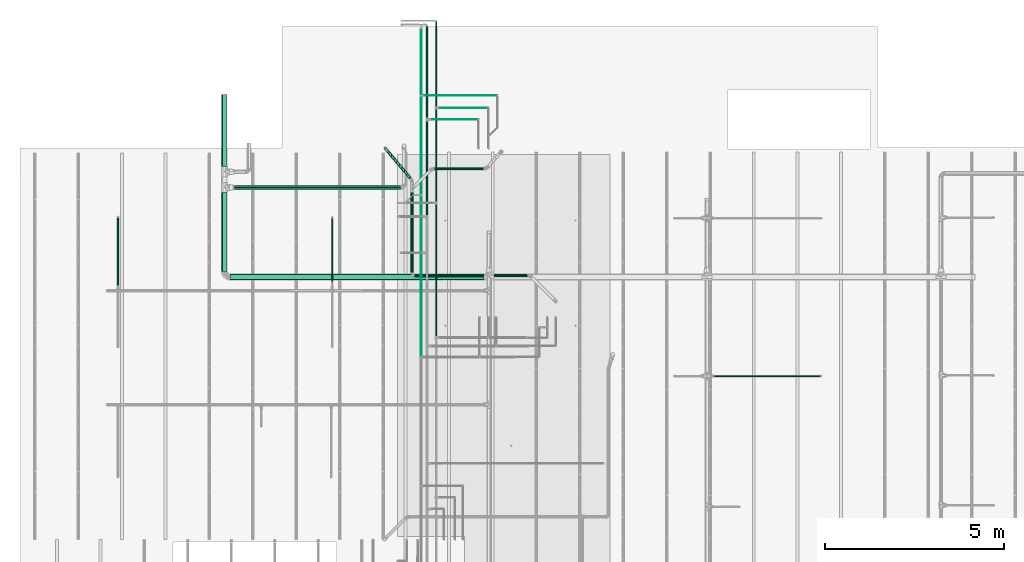
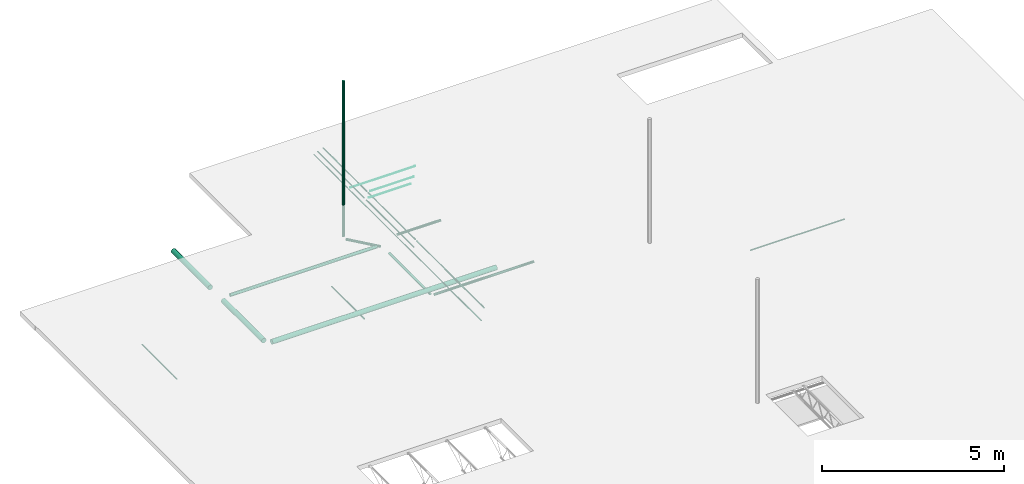
# One storey, part 6 of 173: 23 flow segments.
"""IFC2X3 building model written with IfcOpenShell, lengths in feet."""

from ifc_helpers import new_model, entity, si_unit, converted_unit, derived_unit, direction, frame, origin, origin_2d_with_axis, place, context, subcontext, project, spatial, circle, extrude, source, transform, mapped, type_object, type_shapes, element, save


model = new_model("IFC2X3")

# Units and contexts
model_context = context("Model", 3, precision=0.0001, world=origin(), true_north=direction((6.12303176911189e-17, 1.0)))
body_context = subcontext(model_context, "Body", "Model", "MODEL_VIEW")
ifc_project = project(units=[converted_unit("LENGTHUNIT", "FOOT", entity("IfcRatioMeasure", 0.3048), si_unit("LENGTHUNIT", "METRE"), dimensions=[1, 0, 0, 0, 0, 0, 0]), converted_unit("AREAUNIT", "SQUARE FOOT", entity("IfcRatioMeasure", 0.09290304), si_unit("AREAUNIT", "SQUARE_METRE"), dimensions=[2, 0, 0, 0, 0, 0, 0]), converted_unit("VOLUMEUNIT", "CUBIC FOOT", entity("IfcRatioMeasure", 0.028316846592), si_unit("VOLUMEUNIT", "CUBIC_METRE"), dimensions=[3, 0, 0, 0, 0, 0, 0]), converted_unit("PLANEANGLEUNIT", "DEGREE", entity("IfcRatioMeasure", 0.0174532925199433), si_unit("PLANEANGLEUNIT", "RADIAN"), dimensions=[0, 0, 0, 0, 0, 0, 0]), si_unit("MASSUNIT", "GRAM", prefix="KILO"), derived_unit("MASSDENSITYUNIT", [(si_unit("MASSUNIT", "GRAM", prefix="KILO"), 1), (si_unit("LENGTHUNIT", "METRE"), -3)]), si_unit("TIMEUNIT", "SECOND"), si_unit("FREQUENCYUNIT", "HERTZ"), si_unit("THERMODYNAMICTEMPERATUREUNIT", "DEGREE_CELSIUS"), derived_unit("THERMALTRANSMITTANCEUNIT", [(si_unit("MASSUNIT", "GRAM", prefix="KILO"), 1), (si_unit("THERMODYNAMICTEMPERATUREUNIT", "KELVIN"), -1), (si_unit("TIMEUNIT", "SECOND"), -3)]), derived_unit("VOLUMETRICFLOWRATEUNIT", [(si_unit("LENGTHUNIT", "METRE"), 3), (si_unit("TIMEUNIT", "SECOND"), -1)]), si_unit("ELECTRICCURRENTUNIT", "AMPERE"), si_unit("ELECTRICVOLTAGEUNIT", "VOLT"), si_unit("POWERUNIT", "WATT"), si_unit("FORCEUNIT", "NEWTON"), si_unit("ILLUMINANCEUNIT", "LUX"), si_unit("LUMINOUSFLUXUNIT", "LUMEN"), si_unit("LUMINOUSINTENSITYUNIT", "CANDELA"), derived_unit("USERDEFINED", [(si_unit("MASSUNIT", "GRAM", prefix="KILO"), -1), (si_unit("LENGTHUNIT", "METRE"), -2), (si_unit("TIMEUNIT", "SECOND"), 3), (si_unit("LUMINOUSFLUXUNIT", "LUMEN"), 1)]), derived_unit("LINEARVELOCITYUNIT", [(si_unit("LENGTHUNIT", "METRE"), 1), (si_unit("TIMEUNIT", "SECOND"), -1)]), si_unit("PRESSUREUNIT", "PASCAL"), derived_unit("USERDEFINED", [(si_unit("LENGTHUNIT", "METRE"), -2), (si_unit("MASSUNIT", "GRAM", prefix="KILO"), 1), (si_unit("TIMEUNIT", "SECOND"), -2)])], contexts=[model_context])

# Site, building, storey
site_placement = place(None, origin())
site = spatial("IfcSite", under=ifc_project, at=site_placement, CompositionType="ELEMENT")
building_placement = place(site_placement, origin())
building = spatial("IfcBuilding", under=site, at=building_placement, CompositionType="ELEMENT")
storey_placement = place(building_placement, frame((0.0, 0.0, 8.0)))
storey = spatial("IfcBuildingStorey", under=building, at=storey_placement, Name="REF", CompositionType="ELEMENT", Elevation=8.0)

# Flow segments
pipe_segment_type_1 = type_object("IfcPipeSegmentType", Name="Pipe Types:Standard", PredefinedType="NOTDEFINED")
shared_shape_1 = source(origin(), body_context, "Body", "SweptSolid", [
    extrude(circle(Radius=0.130208333333333, at=origin_2d_with_axis()), frame((-3.68513296929002, 42.8931070869327, 9.58398437499999), z_axis=(0.0, 1.0, 0.0), x_axis=(-1.0, 0.0, 0.0)), (0.0, 0.0, 1.0), 7.37635498552616),
])
type_shapes(pipe_segment_type_1, [shared_shape_1])
flow_segment_1_placement = place(storey_placement, frame((0.0, 0.0, -8.0)))
element("IfcFlowSegment", 1, at=flow_segment_1_placement, inside=storey, type_object=pipe_segment_type_1, Name="Pipe Types:Standard:Standard : Pipe Types:Standard", ObjectType="Standard : Pipe Types:Standard", context=body_context, shape_type="MappedRepresentation", body=[
    mapped(shared_shape_1, transform((0.0, 0.0, 0.0), scale=1.0)),
])
pipe_segment_type_2 = type_object("IfcPipeSegmentType", Name="Pipe Types:Standard", PredefinedType="NOTDEFINED")
shared_shape_2 = source(origin(), body_context, "Body", "SweptSolid", [
    extrude(circle(Radius=0.130208333333333, at=origin_2d_with_axis()), frame((-5.96852925804905, 54.1150089853566, 9.58398437499999), z_axis=(0.642787609686544, -0.766044443118974, 0.0), x_axis=(0.766044443118974, 0.642787609686544, 0.0)), (0.0, 0.0, 1.0), 3.30299018056606),
])
type_shapes(pipe_segment_type_2, [shared_shape_2])
flow_segment_2_placement = place(storey_placement, frame((0.0, 0.0, -8.0)))
element("IfcFlowSegment", 2, at=flow_segment_2_placement, inside=storey, type_object=pipe_segment_type_2, Name="Pipe Types:Standard:Standard : Pipe Types:Standard", ObjectType="Standard : Pipe Types:Standard", context=body_context, shape_type="MappedRepresentation", body=[
    mapped(shared_shape_2, transform((0.0, 0.0, 0.0), scale=1.0)),
])
pipe_segment_type_3 = type_object("IfcPipeSegmentType", Name="Pipe Types:Standard", PredefinedType="NOTDEFINED")
shared_shape_3 = source(origin(), body_context, "Body", "SweptSolid", [
    extrude(circle(Radius=0.130208333333333, at=origin_2d_with_axis()), frame((-6.12880438382389, 54.3060174423022, 9.83332820702099)), (0.0, 0.0, 1.0), 17.0839895013123),
])
type_shapes(pipe_segment_type_3, [shared_shape_3])
flow_segment_3_placement = place(storey_placement, frame((0.0, 0.0, -8.0)))
element("IfcFlowSegment", 3, at=flow_segment_3_placement, inside=storey, type_object=pipe_segment_type_3, Name="Pipe Types:Standard:Standard : Pipe Types:Standard", ObjectType="Standard : Pipe Types:Standard", context=body_context, shape_type="MappedRepresentation", body=[
    mapped(shared_shape_3, transform((0.0, 0.0, 0.0), scale=1.0)),
])
pipe_segment_type_4 = type_object("IfcPipeSegmentType", Name="Pipe Types:Standard", PredefinedType="NOTDEFINED")
shared_shape_4 = source(origin(), body_context, "Body", "SweptSolid", [
    extrude(circle(Radius=0.255208333333333, at=origin_2d_with_axis()), frame((-20.9063914924708, 43.0019225797628, 10.4173177083333), z_axis=(0.0, 1.0, 0.0), x_axis=(-1.0, 0.0, 0.0)), (0.0, 0.0, 1.0), 7.24870720132155),
])
type_shapes(pipe_segment_type_4, [shared_shape_4])
flow_segment_4_placement = place(storey_placement, frame((0.0, 0.0, -8.0)))
element("IfcFlowSegment", 4, at=flow_segment_4_placement, inside=storey, type_object=pipe_segment_type_4, Name="Pipe Types:Standard:Standard : Pipe Types:Standard", ObjectType="Standard : Pipe Types:Standard", context=body_context, shape_type="MappedRepresentation", body=[
    mapped(shared_shape_4, transform((0.0, 0.0, 0.0), scale=1.0)),
])
pipe_segment_type_5 = type_object("IfcPipeSegmentType", Name="Pipe Types:Standard", PredefinedType="NOTDEFINED")
shared_shape_5 = source(origin(), body_context, "Body", "SweptSolid", [
    extrude(circle(Radius=0.171875, at=origin_2d_with_axis()), frame((-19.977913802182, 50.7197898860712, 10.4173177083333), z_axis=(1.0, 0.0, 0.0), x_axis=(0.0, -1.0, 0.0)), (0.0, 0.0, 1.0), 15.2368766404199),
])
type_shapes(pipe_segment_type_5, [shared_shape_5])
flow_segment_5_placement = place(storey_placement, frame((0.0, 0.0, -8.0)))
element("IfcFlowSegment", 5, at=flow_segment_5_placement, inside=storey, type_object=pipe_segment_type_5, Name="Pipe Types:Standard:Standard : Pipe Types:Standard", ObjectType="Standard : Pipe Types:Standard", context=body_context, shape_type="MappedRepresentation", body=[
    mapped(shared_shape_5, transform((0.0, 0.0, 0.0), scale=1.0)),
])
pipe_segment_type_6 = type_object("IfcPipeSegmentType", Name="Pipe Types:Standard", PredefinedType="NOTDEFINED")
shared_shape_6 = source(origin(), body_context, "Body", "SweptSolid", [
    extrude(circle(Radius=0.046875, at=origin_2d_with_axis()), frame((-30.6818340641607, 41.7044138566689, 10.4173177083334), z_axis=(0.0, 1.0, 0.0), x_axis=(1.0, 0.0, 0.0)), (0.0, 0.0, 1.0), 6.24139408619316),
])
type_shapes(pipe_segment_type_6, [shared_shape_6])
flow_segment_6_placement = place(storey_placement, frame((0.0, 0.0, -8.0)))
element("IfcFlowSegment", 6, at=flow_segment_6_placement, inside=storey, type_object=pipe_segment_type_6, Name="Pipe Types:Standard:Standard : Pipe Types:Standard", ObjectType="Standard : Pipe Types:Standard", context=body_context, shape_type="MappedRepresentation", body=[
    mapped(shared_shape_6, transform((0.0, 0.0, 0.0), scale=1.0)),
])
pipe_segment_type_7 = type_object("IfcPipeSegmentType", Name="Pipe Types:Standard", PredefinedType="NOTDEFINED")
shared_shape_7 = source(origin(), body_context, "Body", "SweptSolid", [
    extrude(circle(Radius=0.046875, at=origin_2d_with_axis()), frame((-11.0151673974942, 42.0771172687423, 9.91731770833333), z_axis=(0.0, 1.0, 0.0), x_axis=(1.0, 0.0, 0.0)), (0.0, 0.0, 1.0), 5.83595800524938),
])
type_shapes(pipe_segment_type_7, [shared_shape_7])
flow_segment_7_placement = place(storey_placement, frame((0.0, 0.0, -8.0)))
element("IfcFlowSegment", 7, at=flow_segment_7_placement, inside=storey, type_object=pipe_segment_type_7, Name="Pipe Types:Standard:Standard : Pipe Types:Standard", ObjectType="Standard : Pipe Types:Standard", context=body_context, shape_type="MappedRepresentation", body=[
    mapped(shared_shape_7, transform((0.0, 0.0, 0.0), scale=1.0)),
])
pipe_segment_type_8 = type_object("IfcPipeSegmentType", Name="Pipe Types:Standard", PredefinedType="NOTDEFINED")
shared_shape_8 = source(origin(), body_context, "Body", "SweptSolid", [
    extrude(circle(Radius=0.046875, at=origin_2d_with_axis()), frame((24.0754645115229, 33.4088982913682, 10.4173177083333), z_axis=(1.0, 0.0, 0.0), x_axis=(0.0, -1.0, 0.0)), (0.0, 0.0, 1.0), 9.7388451443569),
])
type_shapes(pipe_segment_type_8, [shared_shape_8])
flow_segment_8_placement = place(storey_placement, frame((0.0, 0.0, -8.0)))
element("IfcFlowSegment", 8, at=flow_segment_8_placement, inside=storey, type_object=pipe_segment_type_8, Name="Pipe Types:Standard:Standard : Pipe Types:Standard", ObjectType="Standard : Pipe Types:Standard", context=body_context, shape_type="MappedRepresentation", body=[
    mapped(shared_shape_8, transform((0.0, 0.0, 0.0), scale=1.0)),
])
pipe_segment_type_9 = type_object("IfcPipeSegmentType", Name="Pipe Types:Standard", PredefinedType="NOTDEFINED")
shared_shape_9 = source(origin(), body_context, "Body", "SweptSolid", [
    extrude(circle(Radius=0.0677083333333333, at=origin_2d_with_axis()), frame((-2.31230977659058, 57.1596919829846, 11.0), z_axis=(0.0, 1.0, 0.0), x_axis=(1.0, 0.0, 0.0)), (0.0, 0.0, 1.0), 8.38727033927112),
])
type_shapes(pipe_segment_type_9, [shared_shape_9])
flow_segment_9_placement = place(storey_placement, frame((0.0, 0.0, -8.0)))
element("IfcFlowSegment", 9, at=flow_segment_9_placement, inside=storey, type_object=pipe_segment_type_9, Name="Pipe Types:Standard:Standard : Pipe Types:Standard", ObjectType="Standard : Pipe Types:Standard", context=body_context, shape_type="MappedRepresentation", body=[
    mapped(shared_shape_9, transform((0.0, 0.0, 0.0), scale=1.0)),
])
pipe_segment_type_10 = type_object("IfcPipeSegmentType", Name="Pipe Types:Standard", PredefinedType="NOTDEFINED")
shared_shape_10 = source(origin(), body_context, "Body", "SweptSolid", [
    extrude(circle(Radius=0.0260416666666667, at=origin_2d_with_axis()), frame((-1.91532814929397, 56.9726841089689, 11.0), z_axis=(1.0, 0.0, 0.0), x_axis=(0.0, -1.0, 0.0)), (0.0, 0.0, 1.0), 4.3046785289534),
])
type_shapes(pipe_segment_type_10, [shared_shape_10])
flow_segment_10_placement = place(storey_placement, frame((0.0, 0.0, -8.0)))
element("IfcFlowSegment", 10, at=flow_segment_10_placement, inside=storey, type_object=pipe_segment_type_10, Name="Pipe Types:Standard:Standard : Pipe Types:Standard", ObjectType="Standard : Pipe Types:Standard", context=body_context, shape_type="MappedRepresentation", body=[
    mapped(shared_shape_10, transform((0.0, 0.0, 0.0), scale=1.0)),
])
pipe_segment_type_11 = type_object("IfcPipeSegmentType", Name="Pipe Types:Standard", PredefinedType="NOTDEFINED")
shared_shape_11 = source(origin(), body_context, "Body", "SweptSolid", [
    extrude(circle(Radius=0.0677083333333333, at=origin_2d_with_axis()), frame((-2.31230977659057, 48.214836814253, 11.0), z_axis=(0.0, 1.0, 0.0), x_axis=(1.0, 0.0, 0.0)), (0.0, 0.0, 1.0), 8.57083942070012),
])
type_shapes(pipe_segment_type_11, [shared_shape_11])
flow_segment_11_placement = place(storey_placement, frame((0.0, 0.0, -8.0)))
element("IfcFlowSegment", 11, at=flow_segment_11_placement, inside=storey, type_object=pipe_segment_type_11, Name="Pipe Types:Standard:Standard : Pipe Types:Standard", ObjectType="Standard : Pipe Types:Standard", context=body_context, shape_type="MappedRepresentation", body=[
    mapped(shared_shape_11, transform((0.0, 0.0, 0.0), scale=1.0)),
])
pipe_segment_type_12 = type_object("IfcPipeSegmentType", Name="Pipe Types:Standard", PredefinedType="NOTDEFINED")
shared_shape_12 = source(origin(), body_context, "Body", "SweptSolid", [
    extrude(circle(Radius=0.046875, at=origin_2d_with_axis()), frame((-1.47897644325722, 37.0434757378257, 10.8333333333333), z_axis=(0.0, 1.0, 0.0), x_axis=(-1.0, 0.0, 0.0)), (0.0, 0.0, 1.0), 12.1357056652208),
])
type_shapes(pipe_segment_type_12, [shared_shape_12])
flow_segment_12_placement = place(storey_placement, frame((0.0, 0.0, -8.0)))
element("IfcFlowSegment", 12, at=flow_segment_12_placement, inside=storey, type_object=pipe_segment_type_12, Name="Pipe Types:Standard:Standard : Pipe Types:Standard", ObjectType="Standard : Pipe Types:Standard", context=body_context, shape_type="MappedRepresentation", body=[
    mapped(shared_shape_12, transform((0.0, 0.0, 0.0), scale=1.0)),
])
pipe_segment_type_13 = type_object("IfcPipeSegmentType", Name="Pipe Types:Standard", PredefinedType="NOTDEFINED")
shared_shape_13 = source(origin(), body_context, "Body", "SweptSolid", [
    extrude(circle(Radius=0.046875, at=origin_2d_with_axis()), frame((-1.47897644325722, 49.4285252350675, 10.8333333333333), z_axis=(0.0, 1.0, 0.0), x_axis=(-1.0, 0.0, 0.0)), (0.0, 0.0, 1.0), 8.45626372999633),
])
type_shapes(pipe_segment_type_13, [shared_shape_13])
flow_segment_13_placement = place(storey_placement, frame((0.0, 0.0, -8.0)))
element("IfcFlowSegment", 13, at=flow_segment_13_placement, inside=storey, type_object=pipe_segment_type_13, Name="Pipe Types:Standard:Standard : Pipe Types:Standard", ObjectType="Standard : Pipe Types:Standard", context=body_context, shape_type="MappedRepresentation", body=[
    mapped(shared_shape_13, transform((0.0, 0.0, 0.0), scale=1.0)),
])
pipe_segment_type_14 = type_object("IfcPipeSegmentType", Name="Pipe Types:Standard", PredefinedType="NOTDEFINED")
shared_shape_14 = source(origin(), body_context, "Body", "SweptSolid", [
    extrude(circle(Radius=0.0260416666666667, at=origin_2d_with_axis()), frame((-1.186981692601, 58.0094608810743, 10.8333333333333), z_axis=(1.0, 0.0, 0.0), x_axis=(0.0, -1.0, 0.0)), (0.0, 0.0, 1.0), 4.49299873892711),
])
type_shapes(pipe_segment_type_14, [shared_shape_14])
flow_segment_14_placement = place(storey_placement, frame((0.0, 0.0, -8.0)))
element("IfcFlowSegment", 14, at=flow_segment_14_placement, inside=storey, type_object=pipe_segment_type_14, Name="Pipe Types:Standard:Standard : Pipe Types:Standard", ObjectType="Standard : Pipe Types:Standard", context=body_context, shape_type="MappedRepresentation", body=[
    mapped(shared_shape_14, transform((0.0, 0.0, 0.0), scale=1.0)),
])
pipe_segment_type_15 = type_object("IfcPipeSegmentType", Name="Pipe Types:Standard", PredefinedType="NOTDEFINED")
shared_shape_15 = source(origin(), body_context, "Body", "SweptSolid", [
    extrude(circle(Radius=0.046875, at=origin_2d_with_axis()), frame((-1.47897644325719, 58.1341327970848, 10.8333333333333), z_axis=(0.0, 1.0, 0.0), x_axis=(-1.0, 0.0, 0.0)), (0.0, 0.0, 1.0), 7.83145811302411),
])
type_shapes(pipe_segment_type_15, [shared_shape_15])
flow_segment_15_placement = place(storey_placement, frame((0.0, 0.0, -8.0)))
element("IfcFlowSegment", 15, at=flow_segment_15_placement, inside=storey, type_object=pipe_segment_type_15, Name="Pipe Types:Standard:Standard : Pipe Types:Standard", ObjectType="Standard : Pipe Types:Standard", context=body_context, shape_type="MappedRepresentation", body=[
    mapped(shared_shape_15, transform((0.0, 0.0, 0.0), scale=1.0)),
])
pipe_segment_type_16 = type_object("IfcPipeSegmentType", Name="Pipe Types:Standard", PredefinedType="NOTDEFINED")
shared_shape_16 = source(origin(), body_context, "Body", "SweptSolid", [
    extrude(circle(Radius=0.0364583333333333, at=origin_2d_with_axis()), frame((-2.82504298847784, 35.2338590686775, 11.0), z_axis=(0.0, 1.0, 0.0), x_axis=(-1.0, 0.0, 0.0)), (0.0, 0.0, 1.0), 14.698453585842),
])
type_shapes(pipe_segment_type_16, [shared_shape_16])
flow_segment_16_placement = place(storey_placement, frame((0.0, 0.0, -8.0)))
element("IfcFlowSegment", 16, at=flow_segment_16_placement, inside=storey, type_object=pipe_segment_type_16, Name="Pipe Types:Standard:Standard : Pipe Types:Standard", ObjectType="Standard : Pipe Types:Standard", context=body_context, shape_type="MappedRepresentation", body=[
    mapped(shared_shape_16, transform((0.0, 0.0, 0.0), scale=1.0)),
])
pipe_segment_type_17 = type_object("IfcPipeSegmentType", Name="Pipe Types:Standard", PredefinedType="NOTDEFINED")
shared_shape_17 = source(origin(), body_context, "Body", "SweptSolid", [
    extrude(circle(Radius=0.0364583333333333, at=origin_2d_with_axis()), frame((-2.82504298847784, 50.1226013684303, 11.0), z_axis=(0.0, 1.0, 0.0), x_axis=(-1.0, 0.0, 0.0)), (0.0, 0.0, 1.0), 8.95244134638102),
])
type_shapes(pipe_segment_type_17, [shared_shape_17])
flow_segment_17_placement = place(storey_placement, frame((0.0, 0.0, -8.0)))
element("IfcFlowSegment", 17, at=flow_segment_17_placement, inside=storey, type_object=pipe_segment_type_17, Name="Pipe Types:Standard:Standard : Pipe Types:Standard", ObjectType="Standard : Pipe Types:Standard", context=body_context, shape_type="MappedRepresentation", body=[
    mapped(shared_shape_17, transform((0.0, 0.0, 0.0), scale=1.0)),
])
pipe_segment_type_18 = type_object("IfcPipeSegmentType", Name="Pipe Types:Standard", PredefinedType="NOTDEFINED")
shared_shape_18 = source(origin(), body_context, "Body", "SweptSolid", [
    extrude(circle(Radius=0.0260416666666667, at=origin_2d_with_axis()), frame((-2.60522671551191, 59.1701870717667, 11.0), z_axis=(1.0, 0.0, 0.0), x_axis=(0.0, -1.0, 0.0)), (0.0, 0.0, 1.0), 6.73184388328407),
])
type_shapes(pipe_segment_type_18, [shared_shape_18])
flow_segment_18_placement = place(storey_placement, frame((0.0, 0.0, -8.0)))
element("IfcFlowSegment", 18, at=flow_segment_18_placement, inside=storey, type_object=pipe_segment_type_18, Name="Pipe Types:Standard:Standard : Pipe Types:Standard", ObjectType="Standard : Pipe Types:Standard", context=body_context, shape_type="MappedRepresentation", body=[
    mapped(shared_shape_18, transform((0.0, 0.0, 0.0), scale=1.0)),
])
pipe_segment_type_19 = type_object("IfcPipeSegmentType", Name="Pipe Types:Standard", PredefinedType="NOTDEFINED")
shared_shape_19 = source(origin(), body_context, "Body", "SweptSolid", [
    extrude(circle(Radius=0.0364583333333333, at=origin_2d_with_axis()), frame((-2.82504298847784, 59.2653314287221, 11.0), z_axis=(0.0, 1.0, 0.0), x_axis=(-1.0, 0.0, 0.0)), (0.0, 0.0, 1.0), 6.00932118224753),
])
type_shapes(pipe_segment_type_19, [shared_shape_19])
flow_segment_19_placement = place(storey_placement, frame((0.0, 0.0, -8.0)))
element("IfcFlowSegment", 19, at=flow_segment_19_placement, inside=storey, type_object=pipe_segment_type_19, Name="Pipe Types:Standard:Standard : Pipe Types:Standard", ObjectType="Standard : Pipe Types:Standard", context=body_context, shape_type="MappedRepresentation", body=[
    mapped(shared_shape_19, transform((0.0, 0.0, 0.0), scale=1.0)),
])
pipe_segment_type_20 = type_object("IfcPipeSegmentType", Name="Pipe Types:Standard", PredefinedType="NOTDEFINED")
shared_shape_20 = source(origin(), body_context, "Body", "SweptSolid", [
    extrude(circle(Radius=0.130208333333333, at=origin_2d_with_axis()), frame((-3.43578913726906, 42.6437632549117, 9.58398437499999), z_axis=(1.0, 0.0, 0.0), x_axis=(0.0, 1.0, 0.0)), (0.0, 0.0, 1.0), 10.3345741849688),
])
type_shapes(pipe_segment_type_20, [shared_shape_20])
flow_segment_20_placement = place(storey_placement, frame((0.0, 0.0, -8.0)))
element("IfcFlowSegment", 20, at=flow_segment_20_placement, inside=storey, type_object=pipe_segment_type_20, Name="Pipe Types:Standard:Standard : Pipe Types:Standard", ObjectType="Standard : Pipe Types:Standard", context=body_context, shape_type="MappedRepresentation", body=[
    mapped(shared_shape_20, transform((0.0, 0.0, 0.0), scale=1.0)),
])
pipe_segment_type_21 = type_object("IfcPipeSegmentType", Name="Pipe Types:Standard", PredefinedType="NOTDEFINED")
shared_shape_21 = source(origin(), body_context, "Body", "SweptSolid", [
    extrude(circle(Radius=0.130208333333333, at=origin_2d_with_axis()), frame((-1.6090966192038, 52.4482274017035, 9.58398437499999), z_axis=(1.0, 0.0, 0.0), x_axis=(0.0, -1.0, 0.0)), (0.0, 0.0, 1.0), 4.50131233595806),
])
type_shapes(pipe_segment_type_21, [shared_shape_21])
flow_segment_21_placement = place(storey_placement, frame((0.0, 0.0, -8.0)))
element("IfcFlowSegment", 21, at=flow_segment_21_placement, inside=storey, type_object=pipe_segment_type_21, Name="Pipe Types:Standard:Standard : Pipe Types:Standard", ObjectType="Standard : Pipe Types:Standard", context=body_context, shape_type="MappedRepresentation", body=[
    mapped(shared_shape_21, transform((0.0, 0.0, 0.0), scale=1.0)),
])
pipe_segment_type_22 = type_object("IfcPipeSegmentType", Name="Pipe Types:Standard", PredefinedType="NOTDEFINED")
shared_shape_22 = source(origin(), body_context, "Body", "SweptSolid", [
    extrude(circle(Radius=0.255208333333333, at=origin_2d_with_axis()), frame((-20.9063914924708, 52.6298521645678, 10.4173177083333), z_axis=(0.0, 1.0, 0.0), x_axis=(-1.0, 0.0, 0.0)), (0.0, 0.0, 1.0), 6.63018480727526),
])
type_shapes(pipe_segment_type_22, [shared_shape_22])
flow_segment_22_placement = place(storey_placement, frame((0.0, 0.0, -8.0)))
element("IfcFlowSegment", 22, at=flow_segment_22_placement, inside=storey, type_object=pipe_segment_type_22, Name="Pipe Types:Standard:Standard : Pipe Types:Standard", ObjectType="Standard : Pipe Types:Standard", context=body_context, shape_type="MappedRepresentation", body=[
    mapped(shared_shape_22, transform((0.0, 0.0, 0.0), scale=1.0)),
])
pipe_segment_type_23 = type_object("IfcPipeSegmentType", Name="Pipe Types:Standard", PredefinedType="NOTDEFINED")
shared_shape_23 = source(origin(), body_context, "Body", "SweptSolid", [
    extrude(circle(Radius=0.255208333333333, at=origin_2d_with_axis()), frame((-20.4077038284288, 42.5032349157208, 10.4173177083333), z_axis=(1.0, 0.0, 0.0), x_axis=(0.0, -1.0, 0.0)), (0.0, 0.0, 1.0), 23.3348743766971),
])
type_shapes(pipe_segment_type_23, [shared_shape_23])
flow_segment_23_placement = place(storey_placement, frame((0.0, 0.0, -8.0)))
element("IfcFlowSegment", 23, at=flow_segment_23_placement, inside=storey, type_object=pipe_segment_type_23, Name="Pipe Types:Standard:Standard : Pipe Types:Standard", ObjectType="Standard : Pipe Types:Standard", context=body_context, shape_type="MappedRepresentation", body=[
    mapped(shared_shape_23, transform((0.0, 0.0, 0.0), scale=1.0)),
])

save(model, "model.ifc")
